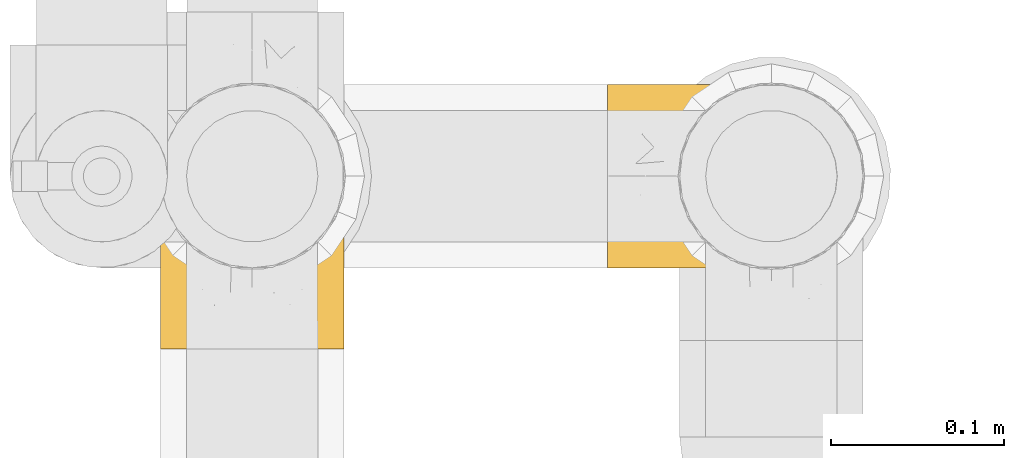
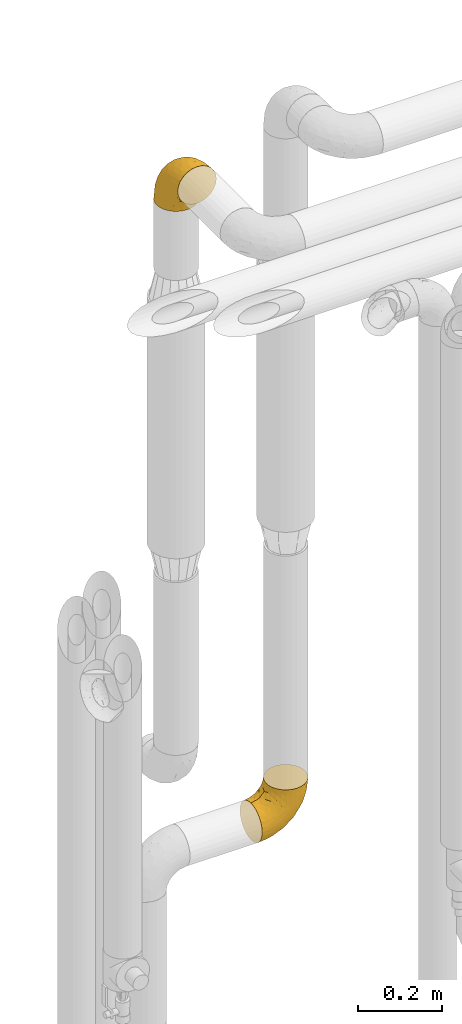
# One storey, part 321 of 827: 2 coverings.
"""IFC2X3 building model written with IfcOpenShell, lengths in millimetres."""

from ifc_helpers import new_model, entity, si_unit, converted_unit, derived_unit, direction, frame, origin, place, context, subcontext, project, spatial, faceted_brep, element, save


model = new_model("IFC2X3")

# Units and contexts
model_context = context("Model", 3, precision=0.01, world=origin(), true_north=direction((6.12303176911189e-17, 1.0)))
body_context = subcontext(model_context, "Body", "Model", "MODEL_VIEW")
ifc_project = project(units=[si_unit("LENGTHUNIT", "METRE", prefix="MILLI"), si_unit("AREAUNIT", "SQUARE_METRE"), si_unit("VOLUMEUNIT", "CUBIC_METRE"), converted_unit("PLANEANGLEUNIT", "DEGREE", entity("IfcRatioMeasure", 0.0174532925199433), si_unit("PLANEANGLEUNIT", "RADIAN"), dimensions=[0, 0, 0, 0, 0, 0, 0]), si_unit("MASSUNIT", "GRAM", prefix="KILO"), derived_unit("MASSDENSITYUNIT", [(si_unit("MASSUNIT", "GRAM", prefix="KILO"), 1), (si_unit("LENGTHUNIT", "METRE"), -3)]), derived_unit("MOMENTOFINERTIAUNIT", [(si_unit("LENGTHUNIT", "METRE"), 4)]), si_unit("TIMEUNIT", "SECOND"), si_unit("FREQUENCYUNIT", "HERTZ"), si_unit("THERMODYNAMICTEMPERATUREUNIT", "DEGREE_CELSIUS"), derived_unit("THERMALTRANSMITTANCEUNIT", [(si_unit("MASSUNIT", "GRAM", prefix="KILO"), 1), (si_unit("THERMODYNAMICTEMPERATUREUNIT", "KELVIN"), -1), (si_unit("TIMEUNIT", "SECOND"), -3)]), derived_unit("VOLUMETRICFLOWRATEUNIT", [(si_unit("LENGTHUNIT", "METRE"), 3), (si_unit("TIMEUNIT", "SECOND"), -1)]), derived_unit("MASSFLOWRATEUNIT", [(si_unit("MASSUNIT", "GRAM", prefix="KILO"), 1), (si_unit("TIMEUNIT", "SECOND"), -1)]), derived_unit("ROTATIONALFREQUENCYUNIT", [(si_unit("TIMEUNIT", "SECOND"), -1)]), si_unit("ELECTRICCURRENTUNIT", "AMPERE"), si_unit("ELECTRICVOLTAGEUNIT", "VOLT"), si_unit("POWERUNIT", "WATT"), si_unit("FORCEUNIT", "NEWTON", prefix="KILO"), si_unit("ILLUMINANCEUNIT", "LUX"), si_unit("LUMINOUSFLUXUNIT", "LUMEN"), si_unit("LUMINOUSINTENSITYUNIT", "CANDELA"), derived_unit("USERDEFINED", [(si_unit("MASSUNIT", "GRAM", prefix="KILO"), -1), (si_unit("LENGTHUNIT", "METRE"), -2), (si_unit("TIMEUNIT", "SECOND"), 3), (si_unit("LUMINOUSFLUXUNIT", "LUMEN"), 1)]), derived_unit("LINEARVELOCITYUNIT", [(si_unit("LENGTHUNIT", "METRE"), 1), (si_unit("TIMEUNIT", "SECOND"), -1)]), si_unit("PRESSUREUNIT", "PASCAL"), derived_unit("USERDEFINED", [(si_unit("LENGTHUNIT", "METRE"), -2), (si_unit("MASSUNIT", "GRAM", prefix="KILO"), 1), (si_unit("TIMEUNIT", "SECOND"), -2)]), derived_unit("LINEARFORCEUNIT", [(si_unit("MASSUNIT", "GRAM", prefix="KILO"), 1), (si_unit("LENGTHUNIT", "METRE"), 1), (si_unit("TIMEUNIT", "SECOND"), -2), (si_unit("LENGTHUNIT", "METRE"), -1)]), derived_unit("PLANARFORCEUNIT", [(si_unit("MASSUNIT", "GRAM", prefix="KILO"), 1), (si_unit("LENGTHUNIT", "METRE"), 1), (si_unit("TIMEUNIT", "SECOND"), -2), (si_unit("LENGTHUNIT", "METRE"), -2)])], contexts=[model_context])

# Site, building, storey
site_placement = place(None, origin())
site = spatial("IfcSite", under=ifc_project, at=site_placement, CompositionType="ELEMENT")
building_placement = place(site_placement, origin())
building = spatial("IfcBuilding", under=site, at=building_placement, CompositionType="ELEMENT")
storey_placement = place(building_placement, frame((0.0, 0.0, 28200.0)))
storey = spatial("IfcBuildingStorey", under=building, at=storey_placement, Name="08", CompositionType="ELEMENT", Elevation=28200.0)

# Coverings
covering_1_placement = place(storey_placement, frame((31659.31, 19298.79, 870.62)))
element("IfcCovering", 1, at=covering_1_placement, inside=storey, Name=":ADSK_", ObjectType=":ADSK_", PredefinedType="INSULATION", context=body_context, shape_type="Brep", body=[
    faceted_brep([(148.32, 42.85, 149.65), (149.65, 54.65, 149.65), (148.31, 66.46, 149.65), (144.39, 77.67, 149.65), (138.06, 87.73, 149.65), (129.66, 96.13, 149.65), (119.6, 102.45, 149.65), (108.39, 106.37, 149.65), (96.6, 107.7, 149.65), (84.79, 106.36, 149.65), (73.57, 102.44, 149.65), (63.51, 96.11, 149.65), (55.11, 87.71, 149.65), (48.79, 77.65, 149.65), (44.87, 66.44, 149.65), (43.55, 54.65, 149.65), (44.88, 42.84, 149.65), (48.8, 31.62, 149.65), (55.13, 21.56, 149.65), (63.53, 13.16, 149.65), (73.59, 6.84, 149.65), (84.8, 2.92, 149.65), (96.6, 1.6, 149.65), (108.41, 2.93, 149.65), (119.62, 6.85, 149.65), (129.68, 13.18, 149.65), (138.08, 21.58, 149.65), (144.4, 31.64, 149.65), (1.6, 68.38, 105.89), (1.6, 81.17, 100.59), (1.6, 92.16, 92.16), (1.6, 100.59, 81.17), (1.6, 105.89, 68.38), (1.6, 107.7, 54.65), (1.6, 105.89, 40.91), (1.6, 100.59, 28.12), (1.6, 92.16, 17.13), (1.6, 81.17, 8.7), (1.6, 68.38, 3.4), (1.6, 54.65, 1.6), (1.6, 40.91, 3.4), (1.6, 28.12, 8.7), (1.6, 17.13, 17.13), (1.6, 8.7, 28.12), (1.6, 3.4, 40.91), (1.6, 1.6, 54.65), (1.6, 3.4, 68.38), (1.6, 8.7, 81.17), (1.6, 17.13, 92.16), (1.6, 28.12, 100.59), (1.6, 40.91, 105.89), (1.6, 54.65, 107.7), (27.97, 23.76, 14.05), (37.09, 35.87, 9.45), (58.27, 25.52, 22.36), (27.13, 45.07, 4.7), (39.91, 54.65, 6.64), (109.11, 12.57, 81.47), (94.41, 15.93, 56.83), (110.94, 24.82, 64.02), (89.69, 37.92, 34.04), (75.62, 54.65, 21.43), (106.28, 54.65, 44.96), (60.12, 5.82, 49.8), (41.41, 8.38, 35.43), (63.22, 10.19, 42.1), (32.05, 3.86, 43.59), (52.13, 2.5, 57.88), (123.27, 19.48, 91.8), (129.32, 29.7, 88.01), (138.3, 28.0, 115.65), (62.95, 35.28, 18.94), (55.89, 45.15, 12.83), (37.4, 14.54, 24.96), (144.6, 54.65, 111.33), (142.66, 38.55, 113.8), (117.85, 40.99, 60.89), (134.01, 43.24, 86.24), (89.25, 8.56, 65.84), (103.34, 2.51, 124.58), (113.52, 5.69, 121.36), (57.43, 1.6, 72.79), (44.19, 1.6, 66.04), (30.95, 1.6, 59.29), (77.98, 3.22, 73.26), (132.66, 18.7, 121.69), (121.52, 11.86, 109.82), (86.93, 24.78, 40.11), (68.4, 15.99, 36.57), (78.45, 1.6, 93.81), (67.94, 1.6, 83.3), (94.53, 1.6, 136.6), (91.95, 1.6, 120.29), (93.36, 2.5, 99.11), (85.2, 1.6, 107.05), (101.45, 5.82, 91.12), (129.81, 54.65, 75.62), (16.27, 1.6, 56.97), (42.46, 32.3, 126.65), (40.4, 25.01, 116.55), (49.71, 18.18, 120.09), (39.4, 3.03, 76.06), (31.26, 6.69, 83.69), (27.7, 3.21, 71.88), (16.7, 2.73, 66.92), (70.67, 3.93, 110.43), (81.69, 2.55, 121.31), (16.68, 7.7, 81.0), (22.57, 54.65, 113.32), (14.26, 54.65, 111.09), (17.68, 41.58, 109.14), (19.58, 17.93, 95.86), (33.49, 14.97, 99.07), (33.01, 22.2, 106.92), (40.69, 43.45, 131.39), (40.15, 54.65, 136.98), (37.93, 54.65, 128.67), (31.04, 40.37, 117.07), (45.29, 8.47, 96.39), (23.55, 29.46, 106.61), (11.36, 32.17, 103.72), (59.1, 3.39, 92.14), (57.42, 7.76, 107.13), (68.96, 2.57, 98.03), (20.38, 11.54, 88.38), (72.46, 6.21, 130.66), (83.66, 2.9, 135.45), (60.66, 11.19, 123.57), (61.01, 14.27, 137.75), (51.85, 22.4, 133.2), (46.07, 34.87, 138.8), (30.25, 54.65, 120.99), (46.65, 4.01, 84.53), (43.0, 16.42, 108.72), (19.58, 91.36, 95.86), (72.44, 103.07, 130.67), (17.67, 67.71, 109.13), (78.45, 107.7, 93.81), (68.97, 106.72, 98.02), (70.65, 105.35, 110.43), (40.69, 65.83, 131.4), (42.45, 76.97, 126.66), (31.04, 68.91, 117.08), (42.99, 92.85, 108.74), (45.18, 100.82, 96.31), (33.46, 94.28, 99.11), (60.64, 98.08, 123.58), (57.37, 101.51, 107.12), (57.43, 107.7, 72.79), (44.19, 107.7, 66.04), (39.35, 106.25, 76.07), (16.27, 107.7, 56.97), (16.7, 106.56, 66.92), (91.95, 107.7, 120.29), (85.2, 107.7, 107.05), (81.68, 106.74, 121.26), (46.68, 105.31, 84.46), (31.26, 102.6, 83.69), (16.68, 101.59, 81.0), (27.7, 106.08, 71.88), (60.99, 95.01, 137.76), (51.84, 86.87, 133.21), (40.41, 84.27, 116.58), (49.72, 91.11, 120.1), (46.06, 74.4, 138.81), (94.53, 107.7, 136.6), (11.35, 77.12, 103.72), (33.02, 87.06, 106.96), (83.65, 106.38, 135.44), (20.38, 97.75, 88.38), (67.94, 107.7, 83.3), (23.53, 79.83, 106.6), (59.12, 105.91, 92.12), (30.95, 107.7, 59.29), (58.27, 83.77, 22.36), (27.97, 85.53, 14.05), (37.4, 94.75, 24.96), (41.41, 100.91, 35.43), (27.21, 64.22, 4.71), (37.09, 73.42, 9.45), (53.2, 64.15, 11.79), (52.13, 106.79, 57.88), (103.34, 106.79, 124.57), (113.5, 103.61, 121.37), (101.45, 103.47, 91.12), (94.41, 93.36, 56.83), (109.08, 96.75, 81.48), (110.95, 84.48, 64.05), (93.36, 106.79, 99.11), (77.98, 106.07, 73.26), (32.05, 105.43, 43.59), (64.63, 73.44, 19.5), (123.25, 89.82, 91.8), (132.65, 90.61, 121.7), (129.32, 79.61, 88.04), (139.96, 81.34, 123.34), (117.85, 68.3, 60.89), (89.69, 71.37, 34.04), (121.51, 97.44, 109.85), (63.23, 99.1, 42.1), (89.17, 100.74, 65.78), (142.66, 70.76, 113.81), (68.4, 93.3, 36.57), (86.94, 84.5, 40.12), (60.12, 103.47, 49.8), (133.2, 68.73, 86.08)], [[[0, 1, 2, 3, 4, 5, 6, 7, 8, 9, 10, 11, 12, 13, 14, 15, 16, 17, 18, 19, 20, 21, 22, 23, 24, 25, 26, 27]], [[28, 29, 30, 31, 32, 33, 34, 35, 36, 37, 38, 39, 40, 41, 42, 43, 44, 45, 46, 47, 48, 49, 50, 51]], [[52, 53, 54]], [[55, 39, 56]], [[57, 58, 59]], [[60, 61, 62]], [[63, 64, 65]], [[66, 63, 67]], [[68, 69, 70]], [[53, 71, 54]], [[41, 40, 53]], [[53, 72, 71]], [[73, 42, 52]], [[42, 41, 52]], [[74, 0, 75]], [[69, 76, 77]], [[43, 73, 64]], [[45, 44, 66]], [[57, 78, 58]], [[23, 79, 80]], [[67, 81, 82, 83]], [[67, 84, 81]], [[24, 23, 80]], [[25, 85, 26]], [[86, 85, 25]], [[42, 73, 43]], [[0, 27, 75]], [[25, 24, 86]], [[70, 26, 85]], [[0, 74, 1]], [[68, 85, 86]], [[66, 64, 63]], [[60, 59, 87]], [[54, 87, 88]], [[76, 60, 62]], [[84, 89, 90, 81]], [[79, 22, 91, 92]], [[77, 74, 75]], [[93, 92, 94, 89]], [[80, 86, 24]], [[40, 55, 53]], [[76, 59, 60]], [[93, 84, 95]], [[76, 62, 96]], [[55, 72, 53]], [[70, 27, 26]], [[75, 70, 69]], [[78, 84, 63]], [[93, 79, 92]], [[95, 86, 80]], [[77, 76, 96]], [[59, 69, 68]], [[57, 68, 86]], [[68, 57, 59]], [[59, 58, 87]], [[76, 69, 59]], [[88, 87, 58]], [[87, 54, 71]], [[86, 95, 57]], [[78, 57, 95]], [[84, 78, 95]], [[78, 63, 65]], [[58, 78, 65]], [[54, 88, 73]], [[84, 93, 89]], [[79, 95, 80]], [[79, 93, 95]], [[22, 79, 23]], [[66, 83, 97, 45]], [[84, 67, 63]], [[83, 66, 67]], [[64, 44, 43]], [[64, 66, 44]], [[65, 73, 88]], [[53, 52, 41]], [[73, 52, 54]], [[73, 65, 64]], [[65, 88, 58]], [[39, 55, 40]], [[72, 55, 56]], [[56, 61, 72]], [[60, 72, 61]], [[72, 60, 71]], [[87, 71, 60]], [[27, 70, 75]], [[68, 70, 85]], [[74, 77, 96]], [[69, 77, 75]], [[98, 99, 100]], [[46, 45, 97]], [[101, 102, 103]], [[103, 104, 83]], [[105, 94, 106]], [[107, 103, 102]], [[108, 109, 51, 110]], [[111, 112, 113]], [[114, 115, 116]], [[47, 104, 107]], [[110, 117, 108]], [[49, 48, 111]], [[102, 118, 112]], [[119, 120, 111]], [[50, 49, 120]], [[121, 122, 118]], [[105, 123, 89]], [[124, 48, 107]], [[20, 19, 125]], [[121, 81, 90]], [[117, 119, 99]], [[21, 20, 126]], [[22, 21, 91]], [[105, 125, 127]], [[110, 51, 50]], [[19, 128, 125]], [[16, 15, 115]], [[129, 98, 100]], [[126, 91, 21]], [[128, 129, 127]], [[122, 123, 105]], [[114, 117, 98]], [[17, 16, 130]], [[18, 128, 19]], [[129, 18, 17]], [[125, 106, 126]], [[115, 114, 16]], [[130, 129, 17]], [[114, 98, 130]], [[117, 116, 131, 108]], [[99, 119, 113]], [[122, 121, 123]], [[92, 126, 106]], [[105, 127, 122]], [[132, 121, 118]], [[114, 130, 16]], [[129, 130, 98]], [[50, 120, 110]], [[129, 128, 18]], [[125, 128, 127]], [[125, 126, 20]], [[91, 126, 92]], [[105, 89, 94]], [[105, 106, 125]], [[94, 92, 106]], [[100, 122, 127]], [[118, 122, 133]], [[112, 118, 133]], [[132, 118, 102]], [[132, 102, 101]], [[81, 121, 132]], [[82, 103, 83]], [[132, 101, 81]], [[104, 47, 46]], [[124, 107, 102]], [[48, 47, 107]], [[113, 112, 133]], [[112, 111, 124]], [[99, 113, 133]], [[111, 113, 119]], [[99, 133, 100]], [[117, 99, 98]], [[122, 100, 133]], [[127, 129, 100]], [[103, 82, 101]], [[81, 101, 82]], [[112, 124, 102]], [[48, 124, 111]], [[104, 103, 107]], [[46, 97, 104]], [[111, 120, 49]], [[83, 104, 97]], [[110, 120, 119]], [[117, 110, 119]], [[116, 117, 114]], [[89, 123, 90]], [[90, 123, 121]], [[30, 29, 134]], [[11, 10, 135]], [[51, 109, 108, 136]], [[137, 138, 139]], [[140, 141, 142]], [[143, 144, 145]], [[146, 139, 147]], [[148, 149, 150]], [[151, 32, 152]], [[153, 154, 155]], [[156, 150, 157]], [[158, 157, 159]], [[108, 142, 136]], [[31, 158, 152]], [[160, 161, 12]], [[162, 163, 143]], [[140, 142, 116]], [[142, 141, 162]], [[14, 164, 140]], [[14, 140, 115]], [[9, 8, 165]], [[160, 12, 11]], [[141, 164, 161]], [[13, 12, 161]], [[14, 115, 15]], [[28, 166, 29]], [[135, 139, 146]], [[141, 163, 162]], [[135, 146, 160]], [[143, 167, 162]], [[29, 166, 134]], [[116, 142, 108, 131]], [[165, 153, 168]], [[10, 9, 168]], [[168, 135, 10]], [[138, 147, 139]], [[158, 169, 157]], [[14, 13, 164]], [[116, 115, 140]], [[145, 167, 143]], [[135, 160, 11]], [[168, 153, 155]], [[138, 137, 170]], [[157, 144, 156]], [[147, 144, 143]], [[161, 164, 13]], [[140, 164, 141]], [[142, 171, 136]], [[136, 171, 166]], [[161, 160, 146]], [[165, 168, 9]], [[155, 139, 135]], [[139, 154, 137]], [[168, 155, 135]], [[139, 155, 154]], [[144, 147, 172]], [[163, 147, 143]], [[156, 144, 172]], [[157, 169, 145]], [[172, 148, 156]], [[173, 159, 149]], [[159, 157, 150]], [[152, 159, 173]], [[159, 152, 158]], [[31, 30, 158]], [[169, 30, 134]], [[157, 145, 144]], [[167, 134, 171]], [[134, 167, 145]], [[171, 142, 162]], [[162, 167, 171]], [[163, 141, 161]], [[161, 146, 163]], [[147, 163, 146]], [[148, 150, 156]], [[149, 159, 150]], [[30, 169, 158]], [[145, 169, 134]], [[151, 33, 32]], [[31, 152, 32]], [[152, 173, 151]], [[28, 51, 136]], [[134, 166, 171]], [[28, 136, 166]], [[138, 170, 172]], [[147, 138, 172]], [[148, 172, 170]], [[174, 175, 176]], [[35, 34, 177]], [[178, 179, 180]], [[181, 173, 149, 148]], [[182, 183, 184]], [[185, 186, 187]], [[188, 189, 137]], [[190, 33, 151, 173]], [[191, 179, 174]], [[34, 190, 177]], [[39, 38, 178]], [[192, 193, 194]], [[4, 3, 195]], [[175, 179, 37]], [[38, 37, 179]], [[35, 176, 36]], [[196, 62, 197]], [[181, 190, 173]], [[37, 36, 175]], [[183, 6, 198]], [[189, 148, 170, 137]], [[185, 199, 200]], [[3, 2, 201]], [[202, 185, 203]], [[8, 7, 182]], [[200, 184, 186]], [[183, 7, 6]], [[181, 189, 204]], [[200, 189, 184]], [[5, 198, 6]], [[187, 203, 185]], [[195, 3, 201]], [[205, 196, 194]], [[62, 61, 197]], [[186, 198, 192]], [[180, 179, 191]], [[2, 1, 74]], [[198, 193, 192]], [[193, 5, 4]], [[194, 193, 195]], [[2, 74, 201]], [[5, 193, 198]], [[205, 74, 96]], [[188, 137, 154, 153]], [[62, 196, 96]], [[56, 178, 180]], [[198, 184, 183]], [[184, 188, 182]], [[203, 197, 191]], [[205, 194, 201]], [[187, 192, 194]], [[192, 187, 186]], [[194, 196, 187]], [[197, 187, 196]], [[197, 203, 187]], [[202, 174, 176]], [[200, 186, 185]], [[184, 198, 186]], [[199, 185, 202]], [[189, 200, 204]], [[174, 202, 203]], [[176, 177, 199]], [[189, 181, 148]], [[190, 181, 204]], [[190, 204, 177]], [[190, 34, 33]], [[188, 153, 182]], [[189, 188, 184]], [[182, 153, 165, 8]], [[183, 182, 7]], [[199, 177, 204]], [[35, 177, 176]], [[176, 175, 36]], [[179, 175, 174]], [[200, 199, 204]], [[176, 199, 202]], [[203, 191, 174]], [[180, 197, 61]], [[197, 180, 191]], [[61, 56, 180]], [[39, 178, 56]], [[38, 179, 178]], [[194, 195, 201]], [[4, 195, 193]], [[74, 205, 201]], [[96, 196, 205]]]),
])
covering_2_placement = place(storey_placement, frame((31400.81, 19251.84, 2798.49)))
element("IfcCovering", 2, at=covering_2_placement, inside=storey, Name=":ADSK_", ObjectType=":ADSK_", PredefinedType="INSULATION", context=body_context, shape_type="Brep", body=[
    faceted_brep([(2.92, 89.81, 1.6), (1.6, 101.6, 1.6), (2.93, 113.39, 1.6), (6.85, 124.6, 1.6), (13.17, 134.65, 1.6), (21.56, 143.04, 1.6), (31.61, 149.35, 1.6), (42.81, 153.27, 1.6), (54.6, 154.6, 1.6), (66.39, 153.27, 1.6), (77.6, 149.34, 1.6), (87.65, 143.03, 1.6), (96.04, 134.63, 1.6), (102.35, 124.58, 1.6), (106.27, 113.38, 1.6), (107.6, 101.6, 1.6), (106.27, 89.8, 1.6), (102.34, 78.59, 1.6), (96.03, 68.54, 1.6), (87.63, 60.15, 1.6), (77.58, 53.84, 1.6), (66.38, 49.92, 1.6), (54.6, 48.6, 1.6), (42.8, 49.93, 1.6), (31.59, 53.85, 1.6), (21.54, 60.17, 1.6), (13.15, 68.56, 1.6), (6.84, 78.61, 1.6), (54.6, 1.6, 48.6), (68.31, 1.6, 50.4), (81.1, 1.6, 55.7), (92.07, 1.6, 64.12), (100.49, 1.6, 75.1), (105.79, 1.6, 87.88), (107.6, 1.6, 101.6), (105.79, 1.6, 115.31), (100.49, 1.6, 128.1), (92.07, 1.6, 139.07), (81.1, 1.6, 147.49), (68.31, 1.6, 152.79), (54.6, 1.6, 154.6), (40.88, 1.6, 152.79), (28.1, 1.6, 147.49), (17.12, 1.6, 139.07), (8.7, 1.6, 128.1), (3.4, 1.6, 115.31), (1.6, 1.6, 101.6), (3.4, 1.6, 87.88), (8.7, 1.6, 75.1), (17.12, 1.6, 64.12), (28.1, 1.6, 55.7), (40.88, 1.6, 50.4), (23.68, 28.76, 142.04), (35.78, 38.32, 146.56), (25.36, 60.03, 133.43), (45.0, 28.08, 151.4), (54.6, 41.19, 149.38), (12.23, 112.9, 72.28), (16.01, 98.0, 98.0), (24.72, 115.08, 89.87), (37.78, 92.68, 121.11), (54.6, 78.1, 134.1), (54.6, 109.78, 109.78), (5.85, 62.45, 105.96), (8.36, 42.86, 120.54), (10.29, 65.57, 113.72), (3.88, 33.33, 112.54), (2.51, 54.42, 97.83), (19.3, 127.59, 61.57), (29.53, 133.85, 65.08), (27.91, 143.17, 36.39), (35.12, 65.18, 136.67), (45.07, 58.25, 142.79), (14.45, 38.6, 131.01), (54.6, 149.38, 41.19), (38.46, 147.46, 38.61), (40.97, 121.78, 93.37), (43.22, 138.51, 67.07), (8.31, 91.12, 90.02), (2.52, 108.25, 27.89), (2.51, 97.83, 54.42), (5.85, 105.96, 62.45), (1.6, 60.37, 82.5), (1.6, 46.44, 89.6), (1.6, 32.5, 96.7), (3.25, 81.59, 81.59), (5.64, 118.32, 30.75), (18.62, 137.49, 30.43), (11.75, 126.28, 42.41), (25.01, 90.22, 115.06), (16.18, 70.93, 119.19), (1.6, 82.5, 60.37), (1.6, 71.44, 71.44), (1.6, 99.53, 14.63), (1.6, 96.7, 32.5), (1.6, 89.6, 46.44), (54.6, 134.1, 78.1), (1.6, 14.63, 99.53), (4.07, 74.43, 43.44), (6.43, 76.88, 21.51), (11.57, 64.82, 29.36), (3.57, 18.51, 85.57), (3.87, 30.85, 81.02), (9.8, 46.71, 57.3), (16.61, 34.93, 55.1), (12.09, 30.7, 63.43), (4.14, 54.93, 66.19), (8.32, 59.44, 48.0), (41.43, 38.2, 33.65), (28.8, 38.97, 40.15), (32.65, 46.97, 26.48), (43.1, 46.15, 20.15), (35.02, 50.97, 13.33), (9.79, 16.08, 71.81), (18.26, 20.7, 59.96), (29.8, 25.37, 49.14), (32.3, 12.19, 52.42), (41.74, 19.06, 46.93), (2.95, 88.33, 16.97), (2.75, 69.89, 58.65), (22.7, 56.53, 19.14), (6.93, 33.63, 71.41), (2.78, 45.49, 78.84), (23.11, 48.78, 34.22), (14.45, 65.75, 14.32), (54.6, 45.02, 19.58), (14.85, 55.96, 37.1), (2.66, 85.66, 32.09), (54.6, 19.58, 45.02), (37.41, 30.27, 42.39), (54.6, 34.83, 34.83), (17.05, 46.11, 45.6), (92.59, 34.94, 55.11), (92.12, 46.09, 45.59), (99.39, 46.74, 57.27), (106.41, 45.49, 78.84), (105.32, 30.85, 81.02), (102.26, 33.63, 71.41), (67.74, 38.21, 33.63), (107.6, 82.5, 60.37), (107.6, 71.44, 71.44), (105.66, 67.05, 57.07), (105.05, 54.93, 66.19), (100.83, 59.43, 47.89), (67.45, 19.04, 46.94), (102.75, 76.86, 21.51), (76.89, 12.19, 52.42), (94.73, 65.73, 14.31), (86.47, 56.52, 19.14), (105.62, 18.51, 85.57), (107.6, 14.63, 99.53), (90.93, 20.69, 59.96), (79.39, 25.35, 49.15), (99.4, 16.08, 71.81), (86.05, 48.77, 34.21), (94.32, 55.94, 37.09), (66.08, 46.15, 20.15), (107.6, 96.7, 32.5), (107.6, 89.6, 46.44), (106.53, 85.64, 32.11), (107.6, 99.53, 14.63), (76.52, 46.97, 26.48), (74.15, 50.96, 13.33), (107.6, 46.44, 89.6), (107.6, 32.5, 96.7), (105.12, 74.4, 43.45), (97.61, 64.8, 29.35), (80.37, 38.97, 40.15), (71.78, 30.28, 42.38), (106.23, 88.31, 16.98), (97.1, 30.68, 63.43), (107.6, 60.37, 82.5), (83.83, 60.03, 133.43), (85.51, 28.76, 142.04), (94.74, 38.6, 131.01), (100.83, 42.86, 120.54), (64.19, 28.3, 151.36), (73.41, 38.32, 146.56), (64.13, 55.19, 143.98), (106.68, 54.42, 97.83), (103.34, 105.96, 62.45), (106.67, 108.24, 27.92), (103.56, 118.31, 30.73), (93.18, 98.0, 98.0), (96.98, 112.87, 72.27), (84.48, 115.1, 89.85), (106.68, 97.83, 54.42), (105.94, 81.59, 81.59), (105.31, 33.33, 112.54), (73.56, 66.78, 136.13), (89.91, 127.57, 61.56), (90.59, 137.47, 30.42), (79.68, 133.85, 65.05), (81.31, 144.8, 28.85), (68.22, 121.78, 93.37), (71.41, 92.68, 121.11), (97.45, 126.27, 42.38), (98.9, 65.58, 113.72), (100.89, 91.01, 90.08), (70.75, 147.45, 38.6), (93.0, 70.94, 119.19), (84.17, 90.23, 115.06), (103.34, 62.45, 105.96), (68.84, 137.61, 67.3)], [[[0, 1, 2, 3, 4, 5, 6, 7, 8, 9, 10, 11, 12, 13, 14, 15, 16, 17, 18, 19, 20, 21, 22, 23, 24, 25, 26, 27]], [[28, 29, 30, 31, 32, 33, 34, 35, 36, 37, 38, 39, 40, 41, 42, 43, 44, 45, 46, 47, 48, 49, 50, 51]], [[52, 53, 54]], [[55, 40, 56]], [[57, 58, 59]], [[60, 61, 62]], [[63, 64, 65]], [[66, 63, 67]], [[68, 69, 70]], [[53, 71, 54]], [[42, 41, 53]], [[53, 72, 71]], [[73, 43, 52]], [[43, 42, 52]], [[74, 7, 75]], [[69, 76, 77]], [[44, 73, 64]], [[46, 45, 66]], [[57, 78, 58]], [[79, 80, 81]], [[67, 82, 83, 84]], [[67, 85, 82]], [[3, 2, 86]], [[4, 87, 5]], [[88, 87, 4]], [[43, 73, 44]], [[7, 6, 75]], [[4, 3, 88]], [[70, 5, 87]], [[7, 74, 8]], [[68, 87, 88]], [[66, 64, 63]], [[60, 59, 89]], [[54, 89, 90]], [[76, 60, 62]], [[85, 91, 92, 82]], [[79, 1, 93, 94]], [[77, 74, 75]], [[80, 94, 95, 91]], [[88, 3, 86]], [[41, 55, 53]], [[76, 59, 60]], [[80, 85, 81]], [[76, 62, 96]], [[55, 72, 53]], [[70, 6, 5]], [[75, 70, 69]], [[78, 85, 63]], [[80, 79, 94]], [[81, 88, 86]], [[77, 76, 96]], [[59, 69, 68]], [[57, 68, 88]], [[68, 57, 59]], [[59, 58, 89]], [[76, 69, 59]], [[90, 89, 58]], [[89, 54, 71]], [[88, 81, 57]], [[78, 57, 81]], [[85, 78, 81]], [[78, 63, 65]], [[58, 78, 65]], [[54, 90, 73]], [[85, 80, 91]], [[79, 81, 86]], [[66, 84, 97, 46]], [[85, 67, 63]], [[84, 66, 67]], [[64, 45, 44]], [[86, 2, 79]], [[1, 79, 2]], [[64, 66, 45]], [[65, 73, 90]], [[53, 52, 42]], [[73, 52, 54]], [[73, 65, 64]], [[65, 90, 58]], [[40, 55, 41]], [[72, 55, 56]], [[56, 61, 72]], [[60, 72, 61]], [[72, 60, 71]], [[89, 71, 60]], [[6, 70, 75]], [[68, 70, 87]], [[74, 77, 96]], [[69, 77, 75]], [[98, 99, 100]], [[84, 101, 97]], [[84, 83, 102]], [[97, 101, 47]], [[103, 104, 105]], [[48, 47, 101]], [[103, 106, 107]], [[108, 109, 110]], [[111, 110, 112]], [[113, 49, 48]], [[49, 114, 50]], [[114, 115, 116]], [[117, 28, 51]], [[116, 51, 50]], [[116, 117, 51]], [[118, 94, 93]], [[111, 108, 110]], [[119, 92, 91]], [[112, 120, 24]], [[121, 122, 106]], [[27, 26, 99]], [[115, 114, 104]], [[123, 110, 109]], [[27, 118, 0]], [[1, 0, 93]], [[113, 114, 49]], [[124, 120, 100]], [[26, 124, 99]], [[111, 22, 125]], [[120, 123, 126]], [[118, 93, 0]], [[99, 127, 118]], [[125, 108, 111]], [[128, 129, 130]], [[24, 23, 112]], [[106, 119, 107]], [[120, 25, 24]], [[91, 98, 119]], [[126, 107, 100]], [[25, 124, 26]], [[92, 106, 82]], [[118, 127, 94]], [[23, 22, 111]], [[120, 112, 110]], [[23, 111, 112]], [[108, 125, 130]], [[129, 128, 117]], [[108, 129, 109]], [[104, 109, 115]], [[123, 109, 131]], [[107, 119, 98]], [[106, 92, 119]], [[100, 107, 98]], [[107, 131, 103]], [[27, 99, 118]], [[95, 127, 98]], [[98, 91, 95]], [[120, 124, 25]], [[99, 124, 100]], [[83, 82, 122]], [[101, 102, 113]], [[122, 102, 83]], [[106, 122, 82]], [[102, 122, 121]], [[101, 113, 48]], [[113, 121, 105]], [[113, 102, 121]], [[102, 101, 84]], [[104, 103, 131]], [[121, 106, 103]], [[104, 131, 109]], [[105, 104, 114]], [[126, 123, 131]], [[120, 110, 123]], [[107, 126, 131]], [[120, 126, 100]], [[113, 105, 114]], [[103, 105, 121]], [[114, 116, 50]], [[117, 116, 115]], [[129, 117, 115]], [[117, 128, 28]], [[109, 129, 115]], [[130, 129, 108]], [[98, 127, 99]], [[94, 127, 95]], [[47, 46, 97]], [[132, 133, 134]], [[135, 136, 137]], [[125, 138, 130]], [[139, 140, 141]], [[142, 143, 141]], [[144, 28, 128]], [[18, 17, 145]], [[29, 146, 30]], [[147, 148, 19]], [[145, 147, 18]], [[32, 149, 33]], [[149, 150, 33]], [[31, 30, 151]], [[144, 152, 146]], [[32, 31, 153]], [[133, 143, 134]], [[154, 155, 133]], [[125, 156, 138]], [[133, 155, 143]], [[22, 21, 156]], [[157, 158, 159]], [[16, 15, 160]], [[19, 18, 147]], [[161, 162, 148]], [[20, 19, 148]], [[162, 156, 21]], [[163, 164, 136]], [[145, 165, 166]], [[133, 167, 154]], [[145, 166, 147]], [[168, 167, 152]], [[30, 146, 151]], [[138, 168, 130]], [[160, 157, 169]], [[160, 169, 16]], [[16, 169, 17]], [[165, 143, 166]], [[151, 170, 153]], [[21, 20, 162]], [[171, 142, 140]], [[152, 167, 132]], [[148, 162, 20]], [[156, 162, 161]], [[156, 161, 138]], [[156, 125, 22]], [[167, 138, 161]], [[168, 152, 144]], [[154, 167, 161]], [[132, 167, 133]], [[159, 165, 145]], [[145, 17, 169]], [[165, 158, 139]], [[169, 159, 145]], [[148, 147, 166]], [[141, 143, 165]], [[134, 143, 142]], [[153, 149, 32]], [[135, 171, 163]], [[135, 142, 171]], [[149, 136, 164]], [[142, 135, 137]], [[151, 153, 31]], [[153, 137, 136]], [[163, 136, 135]], [[153, 136, 149]], [[142, 137, 134]], [[132, 170, 151]], [[170, 134, 137]], [[152, 132, 151]], [[161, 148, 154]], [[155, 148, 166]], [[148, 155, 154]], [[143, 155, 166]], [[134, 170, 132]], [[153, 170, 137]], [[29, 28, 144]], [[151, 146, 152]], [[29, 144, 146]], [[128, 130, 168]], [[168, 144, 128]], [[167, 168, 138]], [[157, 159, 169]], [[165, 159, 158]], [[139, 141, 165]], [[140, 142, 141]], [[150, 149, 164]], [[150, 34, 33]], [[172, 173, 174]], [[36, 35, 175]], [[176, 177, 178]], [[179, 164, 163, 171]], [[180, 181, 182]], [[183, 184, 185]], [[186, 187, 139]], [[188, 34, 150, 164]], [[189, 177, 172]], [[35, 188, 175]], [[40, 39, 176]], [[190, 191, 192]], [[11, 10, 193]], [[173, 177, 38]], [[39, 38, 177]], [[36, 174, 37]], [[194, 62, 195]], [[179, 188, 164]], [[38, 37, 173]], [[182, 13, 196]], [[187, 171, 140, 139]], [[183, 197, 198]], [[10, 9, 199]], [[200, 183, 201]], [[15, 14, 181]], [[180, 184, 198]], [[182, 14, 13]], [[179, 187, 202]], [[198, 187, 180]], [[12, 196, 13]], [[185, 201, 183]], [[193, 10, 199]], [[203, 194, 192]], [[62, 61, 195]], [[184, 196, 190]], [[178, 177, 189]], [[9, 8, 74]], [[196, 191, 190]], [[191, 12, 11]], [[192, 191, 193]], [[9, 74, 199]], [[12, 191, 196]], [[203, 74, 96]], [[186, 139, 158, 157]], [[62, 194, 96]], [[56, 176, 178]], [[196, 180, 182]], [[180, 186, 181]], [[201, 195, 189]], [[203, 192, 199]], [[185, 190, 192]], [[190, 185, 184]], [[192, 194, 185]], [[195, 185, 194]], [[195, 201, 185]], [[200, 172, 174]], [[198, 184, 183]], [[180, 196, 184]], [[197, 183, 200]], [[187, 198, 202]], [[172, 200, 201]], [[174, 175, 197]], [[187, 179, 171]], [[188, 179, 202]], [[188, 202, 175]], [[188, 35, 34]], [[186, 157, 181]], [[187, 186, 180]], [[181, 157, 160, 15]], [[14, 182, 181]], [[197, 175, 202]], [[36, 175, 174]], [[174, 173, 37]], [[177, 173, 172]], [[198, 197, 202]], [[174, 197, 200]], [[201, 189, 172]], [[178, 195, 61]], [[195, 178, 189]], [[61, 56, 178]], [[40, 176, 56]], [[39, 177, 176]], [[192, 193, 199]], [[11, 193, 191]], [[74, 203, 199]], [[96, 194, 203]]]),
])

save(model, "model.ifc")
